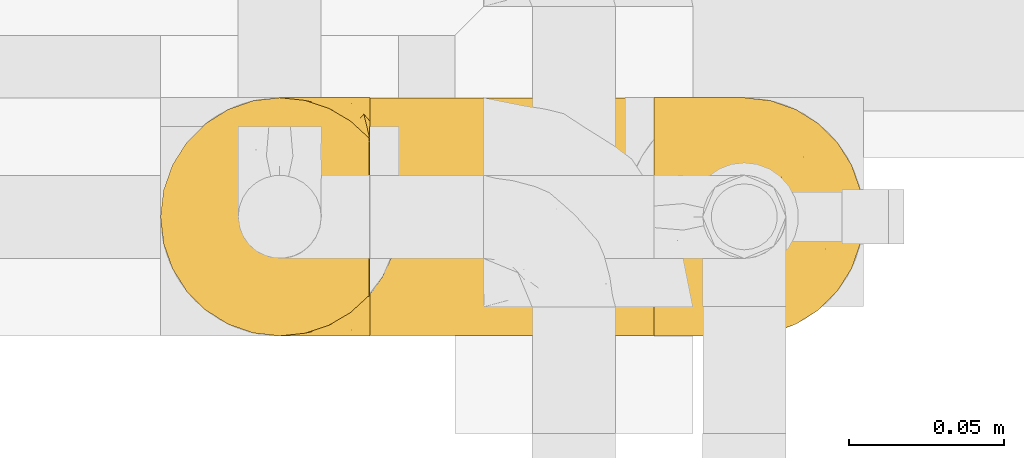
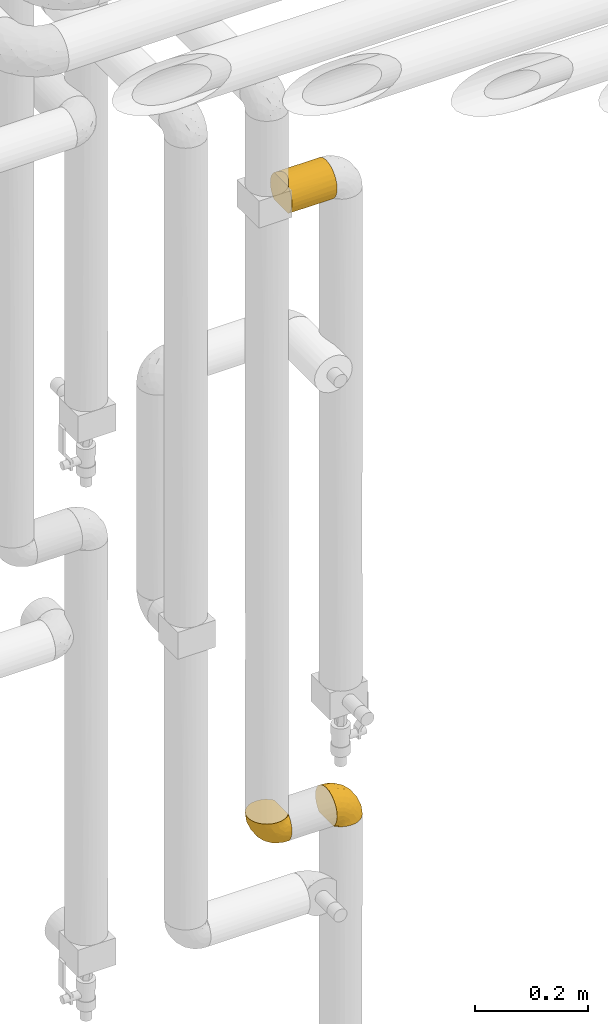
# One storey, part 279 of 827: 3 coverings.
"""IFC2X3 building model written with IfcOpenShell, lengths in millimetres."""

from ifc_helpers import new_model, entity, si_unit, converted_unit, derived_unit, direction, frame, origin, place, context, subcontext, project, spatial, faceted_brep, element, save


model = new_model("IFC2X3")

# Units and contexts
model_context = context("Model", 3, precision=0.01, world=origin(), true_north=direction((6.12303176911189e-17, 1.0)))
body_context = subcontext(model_context, "Body", "Model", "MODEL_VIEW")
ifc_project = project(units=[si_unit("LENGTHUNIT", "METRE", prefix="MILLI"), si_unit("AREAUNIT", "SQUARE_METRE"), si_unit("VOLUMEUNIT", "CUBIC_METRE"), converted_unit("PLANEANGLEUNIT", "DEGREE", entity("IfcRatioMeasure", 0.0174532925199433), si_unit("PLANEANGLEUNIT", "RADIAN"), dimensions=[0, 0, 0, 0, 0, 0, 0]), si_unit("MASSUNIT", "GRAM", prefix="KILO"), derived_unit("MASSDENSITYUNIT", [(si_unit("MASSUNIT", "GRAM", prefix="KILO"), 1), (si_unit("LENGTHUNIT", "METRE"), -3)]), derived_unit("MOMENTOFINERTIAUNIT", [(si_unit("LENGTHUNIT", "METRE"), 4)]), si_unit("TIMEUNIT", "SECOND"), si_unit("FREQUENCYUNIT", "HERTZ"), si_unit("THERMODYNAMICTEMPERATUREUNIT", "DEGREE_CELSIUS"), derived_unit("THERMALTRANSMITTANCEUNIT", [(si_unit("MASSUNIT", "GRAM", prefix="KILO"), 1), (si_unit("THERMODYNAMICTEMPERATUREUNIT", "KELVIN"), -1), (si_unit("TIMEUNIT", "SECOND"), -3)]), derived_unit("VOLUMETRICFLOWRATEUNIT", [(si_unit("LENGTHUNIT", "METRE"), 3), (si_unit("TIMEUNIT", "SECOND"), -1)]), derived_unit("MASSFLOWRATEUNIT", [(si_unit("MASSUNIT", "GRAM", prefix="KILO"), 1), (si_unit("TIMEUNIT", "SECOND"), -1)]), derived_unit("ROTATIONALFREQUENCYUNIT", [(si_unit("TIMEUNIT", "SECOND"), -1)]), si_unit("ELECTRICCURRENTUNIT", "AMPERE"), si_unit("ELECTRICVOLTAGEUNIT", "VOLT"), si_unit("POWERUNIT", "WATT"), si_unit("FORCEUNIT", "NEWTON", prefix="KILO"), si_unit("ILLUMINANCEUNIT", "LUX"), si_unit("LUMINOUSFLUXUNIT", "LUMEN"), si_unit("LUMINOUSINTENSITYUNIT", "CANDELA"), derived_unit("USERDEFINED", [(si_unit("MASSUNIT", "GRAM", prefix="KILO"), -1), (si_unit("LENGTHUNIT", "METRE"), -2), (si_unit("TIMEUNIT", "SECOND"), 3), (si_unit("LUMINOUSFLUXUNIT", "LUMEN"), 1)]), derived_unit("LINEARVELOCITYUNIT", [(si_unit("LENGTHUNIT", "METRE"), 1), (si_unit("TIMEUNIT", "SECOND"), -1)]), si_unit("PRESSUREUNIT", "PASCAL"), derived_unit("USERDEFINED", [(si_unit("LENGTHUNIT", "METRE"), -2), (si_unit("MASSUNIT", "GRAM", prefix="KILO"), 1), (si_unit("TIMEUNIT", "SECOND"), -2)]), derived_unit("LINEARFORCEUNIT", [(si_unit("MASSUNIT", "GRAM", prefix="KILO"), 1), (si_unit("LENGTHUNIT", "METRE"), 1), (si_unit("TIMEUNIT", "SECOND"), -2), (si_unit("LENGTHUNIT", "METRE"), -1)]), derived_unit("PLANARFORCEUNIT", [(si_unit("MASSUNIT", "GRAM", prefix="KILO"), 1), (si_unit("LENGTHUNIT", "METRE"), 1), (si_unit("TIMEUNIT", "SECOND"), -2), (si_unit("LENGTHUNIT", "METRE"), -2)])], contexts=[model_context])

# Site, building, storey
site_placement = place(None, origin())
site = spatial("IfcSite", under=ifc_project, at=site_placement, CompositionType="ELEMENT")
building_placement = place(site_placement, origin())
building = spatial("IfcBuilding", under=site, at=building_placement, CompositionType="ELEMENT")
storey_placement = place(building_placement, frame((0.0, 0.0, 28200.0)))
storey = spatial("IfcBuildingStorey", under=building, at=storey_placement, Name="08", CompositionType="ELEMENT", Elevation=28200.0)

# Coverings
covering_1_placement = place(storey_placement, frame((35112.19, 14884.87, 1199.3)))
element("IfcCovering", 1, at=covering_1_placement, inside=storey, Name=":ADSK_", ObjectType=":ADSK_", PredefinedType="INSULATION", context=body_context, shape_type="Brep", body=[
    faceted_brep([(47.38, 74.68, 1.6), (54.67, 70.1, 1.6), (60.76, 64.01, 1.6), (65.34, 56.72, 1.6), (68.18, 48.6, 1.6), (69.15, 40.05, 1.6), (68.18, 31.49, 1.6), (65.33, 23.36, 1.6), (60.75, 16.07, 1.6), (54.66, 9.98, 1.6), (47.37, 5.4, 1.6), (39.25, 2.56, 1.6), (30.7, 1.6, 1.6), (22.59, 2.46, 1.6), (14.86, 5.01, 1.6), (7.84, 9.13, 1.6), (1.85, 14.62, 1.6), (1.85, 16.82, 1.6), (1.85, 18.56, 1.6), (1.85, 20.52, 1.6), (1.85, 22.49, 1.6), (1.85, 24.46, 1.6), (1.85, 26.42, 1.6), (1.85, 28.39, 1.6), (1.85, 30.36, 1.6), (1.85, 32.55, 1.6), (1.85, 34.75, 1.6), (1.85, 36.94, 1.6), (1.85, 39.13, 1.6), (1.85, 41.33, 1.6), (1.85, 43.52, 1.6), (1.85, 45.72, 1.6), (1.85, 47.91, 1.6), (1.85, 50.11, 1.6), (1.85, 52.3, 1.6), (1.85, 54.49, 1.6), (1.85, 56.69, 1.6), (1.85, 58.88, 1.6), (1.85, 61.08, 1.6), (1.85, 63.27, 1.6), (1.85, 65.47, 1.6), (7.85, 70.97, 1.6), (14.88, 75.09, 1.6), (22.61, 77.64, 1.6), (30.7, 78.5, 1.6), (39.26, 77.53, 1.6), (1.6, 14.62, 1.85), (1.6, 9.12, 7.85), (1.6, 5.0, 14.87), (1.6, 2.46, 22.6), (1.6, 1.6, 30.7), (1.6, 2.91, 40.65), (1.6, 6.75, 49.92), (1.6, 12.86, 57.88), (1.6, 20.82, 63.99), (1.6, 30.09, 67.84), (1.6, 40.05, 69.15), (1.6, 50.0, 67.84), (1.6, 59.27, 63.99), (1.6, 67.23, 57.88), (1.6, 73.34, 49.92), (1.6, 77.19, 40.65), (1.6, 78.5, 30.7), (1.6, 77.63, 22.6), (1.6, 75.09, 14.87), (1.6, 70.97, 7.85), (1.6, 65.47, 1.85), (1.6, 63.27, 1.85), (1.6, 62.29, 1.85), (1.6, 60.7, 1.85), (1.6, 59.11, 1.85), (1.6, 57.52, 1.85), (1.6, 55.93, 1.85), (1.6, 54.34, 1.85), (1.6, 52.76, 1.85), (1.6, 51.17, 1.85), (1.6, 49.58, 1.85), (1.6, 47.99, 1.85), (1.6, 46.4, 1.85), (1.6, 44.81, 1.85), (1.6, 43.22, 1.85), (1.6, 41.63, 1.85), (1.6, 40.05, 1.85), (1.6, 38.46, 1.85), (1.6, 36.87, 1.85), (1.6, 35.28, 1.85), (1.6, 33.69, 1.85), (1.6, 32.1, 1.85), (1.6, 30.51, 1.85), (1.6, 28.92, 1.85), (1.6, 27.33, 1.85), (1.6, 25.37, 1.85), (1.6, 23.4, 1.85), (1.6, 21.21, 1.85), (1.6, 19.01, 1.85), (1.6, 16.82, 1.85), (1.78, 42.32, 1.77), (1.77, 44.02, 1.78), (1.78, 47.13, 1.77), (1.77, 48.74, 1.77), (1.79, 23.57, 1.76), (1.78, 25.13, 1.77), (1.76, 61.34, 1.79), (1.77, 22.02, 1.78), (1.77, 29.72, 1.78), (1.76, 56.73, 1.78), (1.77, 55.14, 1.78), (1.77, 37.66, 1.78), (1.8, 64.12, 1.74), (1.76, 28.13, 1.78), (1.77, 26.62, 1.78), (1.78, 31.46, 1.77), (1.77, 16.16, 1.78), (1.77, 39.16, 1.78), (1.76, 50.37, 1.78), (1.77, 17.69, 1.77), (1.78, 19.17, 1.77), (1.77, 62.78, 1.77), (1.77, 58.35, 1.78), (1.77, 45.53, 1.78), (1.78, 59.91, 1.77), (1.77, 65.47, 1.77), (1.8, 65.47, 1.72), (1.82, 65.47, 1.66), (1.77, 14.62, 1.77), (1.72, 14.62, 1.8), (1.66, 14.62, 1.82), (1.76, 20.59, 1.79), (1.77, 32.99, 1.78), (1.76, 34.48, 1.79), (1.77, 51.91, 1.78), (1.66, 65.47, 1.82), (1.72, 65.47, 1.8), (1.78, 53.48, 1.76), (1.82, 14.62, 1.66), (1.8, 14.62, 1.72), (1.77, 40.77, 1.78), (1.78, 35.97, 1.77), (3.72, 7.84, 9.41), (7.41, 3.53, 17.65), (6.13, 8.32, 7.41), (21.47, 1.6, 21.47), (19.34, 2.19, 15.21), (26.8, 1.6, 16.15), (8.87, 1.6, 28.75), (9.2, 4.57, 13.67), (12.79, 3.96, 12.79), (14.62, 2.28, 19.18), (7.34, 1.6, 29.16), (5.33, 7.69, 9.04), (17.64, 3.53, 7.41), (7.7, 8.32, 5.74), (9.41, 7.84, 3.72), (28.75, 1.6, 8.87), (16.15, 1.6, 26.8), (14.14, 4.34, 9.53), (29.16, 1.6, 7.34), (57.02, 29.63, 37.63), (64.92, 27.34, 17.92), (64.0, 40.05, 27.45), (11.92, 2.39, 37.01), (19.16, 2.43, 34.22), (28.65, 9.07, 45.87), (24.62, 16.64, 56.57), (15.19, 9.54, 52.31), (18.36, 4.52, 42.07), (9.2, 4.52, 44.74), (46.98, 7.49, 21.49), (50.24, 7.49, 11.02), (56.1, 12.85, 15.64), (28.97, 2.35, 26.02), (54.46, 22.66, 36.59), (21.34, 32.9, 65.49), (18.4, 25.33, 63.99), (66.44, 40.05, 15.2), (12.07, 16.64, 60.27), (45.49, 19.99, 45.25), (50.57, 16.37, 35.21), (36.04, 3.26, 22.52), (42.07, 3.75, 12.03), (62.12, 19.58, 13.32), (37.37, 7.5, 35.9), (29.39, 4.04, 33.87), (53.59, 13.94, 25.73), (58.06, 19.58, 26.34), (49.27, 28.21, 46.78), (29.63, 24.75, 59.54), (33.21, 31.42, 60.18), (40.1, 26.2, 53.93), (44.08, 33.36, 53.36), (49.36, 40.05, 49.36), (56.68, 40.05, 38.4), (15.2, 40.05, 66.44), (35.57, 16.14, 50.09), (41.7, 12.85, 41.08), (46.4, 10.47, 31.14), (41.41, 6.49, 28.19), (27.45, 40.05, 64.0), (38.4, 40.05, 56.68), (12.99, 75.57, 43.9), (21.33, 47.37, 65.46), (42.89, 52.91, 52.22), (57.04, 50.46, 37.61), (56.11, 67.23, 15.64), (62.13, 60.5, 13.31), (21.89, 70.55, 50.02), (16.62, 63.45, 59.28), (32.9, 62.61, 53.05), (46.99, 72.6, 21.48), (50.25, 72.6, 11.01), (42.08, 76.34, 12.03), (49.91, 59.34, 41.02), (15.6, 77.76, 35.39), (16.15, 78.5, 26.8), (8.87, 78.5, 28.75), (29.16, 78.5, 7.34), (13.16, 53.16, 65.81), (10.83, 70.55, 53.28), (33.8, 48.88, 59.8), (25.02, 54.76, 61.82), (64.92, 52.74, 17.91), (32.83, 71.93, 41.4), (20.56, 75.79, 40.48), (58.07, 60.5, 26.34), (21.46, 77.86, 31.68), (28.1, 77.64, 27.68), (26.8, 78.5, 16.15), (21.47, 78.5, 21.47), (51.29, 67.23, 28.05), (36.04, 76.82, 22.54), (28.75, 78.5, 8.87), (8.45, 77.8, 37.3), (41.73, 67.23, 41.07), (39.27, 73.2, 32.24), (33.56, 67.66, 47.4), (27.29, 75.99, 35.77), (7.41, 76.57, 17.65), (3.51, 73.21, 11.06), (4.68, 71.93, 8.55), (5.52, 71.07, 6.63), (8.75, 75.09, 12.77), (12.79, 76.13, 12.79), (17.65, 76.57, 7.41), (13.9, 77.69, 18.97), (9.42, 72.26, 3.72), (7.68, 71.77, 5.76), (19.33, 77.9, 15.21), (14.13, 75.75, 9.52)], [[[0, 1, 2, 3, 4, 5, 6, 7, 8, 9, 10, 11, 12, 13, 14, 15, 16, 17, 18, 19, 20, 21, 22, 23, 24, 25, 26, 27, 28, 29, 30, 31, 32, 33, 34, 35, 36, 37, 38, 39, 40, 41, 42, 43, 44, 45]], [[46, 47, 48, 49, 50, 51, 52, 53, 54, 55, 56, 57, 58, 59, 60, 61, 62, 63, 64, 65, 66, 67, 68, 69, 70, 71, 72, 73, 74, 75, 76, 77, 78, 79, 80, 81, 82, 83, 84, 85, 86, 87, 88, 89, 90, 91, 92, 93, 94, 95]], [[96, 97, 30]], [[98, 77, 99]], [[100, 101, 21]], [[69, 68, 102]], [[20, 19, 103]], [[24, 23, 104]], [[20, 103, 100]], [[72, 105, 106]], [[84, 83, 107]], [[89, 88, 104]], [[108, 67, 66]], [[109, 110, 90]], [[111, 25, 24]], [[112, 17, 16]], [[82, 113, 83]], [[109, 23, 22]], [[114, 76, 75]], [[105, 36, 106]], [[104, 111, 24]], [[18, 115, 116]], [[97, 96, 80]], [[67, 108, 117]], [[105, 71, 118]], [[31, 97, 119]], [[102, 120, 69]], [[108, 121, 122, 123, 40]], [[112, 95, 115]], [[17, 115, 18]], [[94, 116, 115]], [[117, 68, 67]], [[38, 117, 39]], [[112, 124, 125, 126, 46]], [[17, 112, 115]], [[70, 120, 118]], [[39, 117, 108]], [[120, 38, 37]], [[120, 37, 118]], [[120, 70, 69]], [[116, 94, 127]], [[128, 86, 129]], [[117, 38, 102]], [[74, 130, 75]], [[99, 33, 32]], [[115, 95, 94]], [[39, 108, 40]], [[108, 66, 131, 132, 121]], [[105, 72, 71]], [[118, 37, 36]], [[71, 70, 118]], [[35, 106, 36]], [[36, 105, 118]], [[35, 133, 106]], [[74, 73, 133]], [[106, 133, 73]], [[99, 114, 33]], [[133, 35, 34]], [[73, 72, 106]], [[95, 112, 46]], [[112, 16, 134, 135, 124]], [[130, 114, 75]], [[99, 76, 114]], [[114, 130, 33]], [[34, 33, 130]], [[78, 77, 98]], [[98, 119, 78]], [[130, 133, 34]], [[133, 130, 74]], [[79, 97, 80]], [[98, 99, 32]], [[98, 32, 31]], [[77, 76, 99]], [[97, 79, 119]], [[136, 96, 29]], [[30, 97, 31]], [[136, 29, 28]], [[81, 80, 96]], [[29, 96, 30]], [[31, 119, 98]], [[119, 79, 78]], [[96, 136, 81]], [[82, 81, 136]], [[113, 107, 83]], [[84, 107, 137]], [[107, 27, 137]], [[113, 28, 107]], [[27, 107, 28]], [[85, 84, 137]], [[137, 27, 26]], [[113, 136, 28]], [[136, 113, 82]], [[109, 89, 104]], [[86, 85, 129]], [[89, 109, 90]], [[111, 87, 128]], [[26, 129, 137]], [[88, 111, 104]], [[25, 111, 128]], [[22, 110, 109]], [[23, 109, 104]], [[110, 91, 90]], [[100, 92, 101]], [[110, 22, 101]], [[91, 110, 101]], [[116, 19, 18]], [[111, 88, 87]], [[127, 103, 19]], [[25, 128, 26]], [[86, 128, 87]], [[128, 129, 26]], [[137, 129, 85]], [[120, 102, 38]], [[117, 102, 68]], [[91, 101, 92]], [[21, 101, 22]], [[93, 92, 103]], [[100, 21, 20]], [[100, 103, 92]], [[127, 93, 103]], [[93, 127, 94]], [[116, 127, 19]], [[126, 138, 47]], [[48, 138, 139]], [[140, 125, 124]], [[141, 142, 143]], [[144, 49, 139]], [[145, 140, 146]], [[48, 139, 49]], [[139, 145, 147]], [[49, 144, 148, 50]], [[126, 125, 149]], [[14, 13, 150]], [[151, 146, 140]], [[149, 140, 145]], [[152, 151, 135]], [[152, 14, 150]], [[16, 15, 134]], [[13, 153, 150]], [[124, 151, 140]], [[141, 147, 142]], [[14, 152, 15]], [[15, 152, 134]], [[47, 46, 126]], [[139, 154, 144]], [[138, 48, 47]], [[125, 140, 149]], [[135, 134, 152]], [[146, 155, 142]], [[145, 146, 147]], [[149, 139, 138]], [[147, 141, 154]], [[147, 146, 142]], [[139, 147, 154]], [[139, 149, 145]], [[149, 138, 126]], [[155, 146, 151]], [[150, 143, 142]], [[152, 155, 151]], [[150, 142, 155]], [[13, 12, 156, 153]], [[153, 143, 150]], [[152, 150, 155]], [[151, 124, 135]], [[157, 158, 159]], [[160, 154, 161]], [[162, 163, 164]], [[165, 166, 160]], [[167, 168, 169]], [[141, 170, 161]], [[156, 12, 11]], [[158, 157, 171]], [[172, 55, 173]], [[158, 6, 174]], [[175, 54, 53]], [[52, 166, 164]], [[52, 164, 53]], [[54, 175, 173]], [[166, 52, 51]], [[176, 177, 171]], [[178, 143, 179]], [[156, 11, 179]], [[8, 7, 180]], [[169, 9, 8]], [[179, 143, 153, 156]], [[179, 11, 10]], [[168, 179, 10]], [[181, 162, 182]], [[179, 167, 178]], [[183, 184, 177]], [[183, 169, 184]], [[176, 171, 185]], [[172, 186, 187]], [[158, 7, 6]], [[159, 158, 174]], [[184, 180, 158]], [[54, 173, 55]], [[180, 169, 8]], [[188, 189, 187]], [[9, 168, 10]], [[186, 188, 187]], [[190, 157, 159, 191]], [[55, 172, 192]], [[176, 193, 194]], [[161, 170, 182]], [[162, 164, 165]], [[175, 164, 163]], [[51, 50, 148]], [[167, 195, 196]], [[178, 182, 170]], [[6, 5, 174]], [[158, 180, 7]], [[169, 180, 184]], [[169, 168, 9]], [[179, 168, 167]], [[182, 162, 165]], [[162, 194, 193]], [[161, 165, 160]], [[195, 181, 196]], [[192, 172, 197]], [[192, 56, 55]], [[189, 190, 198]], [[198, 197, 187]], [[172, 187, 197]], [[185, 189, 188]], [[198, 187, 189]], [[186, 172, 173]], [[173, 163, 186]], [[193, 186, 163]], [[176, 185, 188]], [[185, 157, 190]], [[188, 186, 193]], [[177, 176, 194]], [[188, 193, 176]], [[162, 193, 163]], [[195, 177, 194]], [[171, 177, 184]], [[181, 195, 194]], [[183, 167, 169]], [[162, 181, 194]], [[196, 182, 178]], [[158, 171, 184]], [[171, 157, 185]], [[177, 195, 183]], [[167, 183, 195]], [[182, 196, 181]], [[178, 170, 143]], [[178, 167, 196]], [[164, 175, 53]], [[173, 175, 163]], [[160, 51, 148]], [[164, 166, 165]], [[51, 160, 166]], [[160, 148, 144, 154]], [[141, 161, 154]], [[182, 165, 161]], [[190, 189, 185]], [[143, 170, 141]], [[60, 199, 61]], [[197, 200, 192]], [[201, 190, 202]], [[200, 57, 192]], [[203, 204, 2]], [[205, 206, 207]], [[208, 209, 210]], [[211, 207, 201]], [[212, 213, 214]], [[45, 215, 210]], [[216, 206, 58]], [[45, 44, 215]], [[59, 217, 60]], [[60, 217, 199]], [[0, 45, 210]], [[218, 201, 219]], [[202, 159, 220]], [[205, 221, 222]], [[223, 204, 203]], [[1, 203, 2]], [[57, 200, 216]], [[220, 3, 204]], [[220, 174, 4]], [[1, 0, 209]], [[212, 224, 213]], [[225, 226, 227]], [[228, 223, 203]], [[208, 210, 229]], [[210, 226, 229]], [[3, 220, 4]], [[58, 206, 59]], [[209, 203, 1]], [[202, 220, 223]], [[228, 203, 208]], [[202, 211, 201]], [[3, 2, 204]], [[202, 190, 191, 159]], [[210, 215, 230, 226]], [[199, 212, 231]], [[232, 233, 221]], [[233, 208, 229]], [[207, 206, 219]], [[217, 206, 205]], [[227, 224, 225]], [[233, 232, 228]], [[201, 207, 219]], [[234, 232, 221]], [[218, 219, 200]], [[202, 223, 211]], [[174, 220, 159]], [[174, 5, 4]], [[61, 231, 62]], [[220, 204, 223]], [[210, 209, 0]], [[203, 209, 208]], [[225, 233, 229]], [[224, 227, 213]], [[221, 233, 235]], [[57, 56, 192]], [[198, 218, 197]], [[200, 219, 216]], [[201, 198, 190]], [[197, 218, 200]], [[198, 201, 218]], [[206, 216, 219]], [[58, 57, 216]], [[231, 212, 214]], [[222, 212, 199]], [[228, 211, 223]], [[207, 211, 232]], [[62, 231, 214]], [[199, 231, 61]], [[233, 228, 208]], [[211, 228, 232]], [[222, 221, 235]], [[234, 205, 207]], [[206, 217, 59]], [[199, 217, 205]], [[205, 222, 199]], [[224, 222, 235]], [[222, 224, 212]], [[224, 235, 225]], [[233, 225, 235]], [[226, 225, 229]], [[205, 234, 221]], [[207, 232, 234]], [[63, 214, 236]], [[214, 213, 236]], [[214, 63, 62]], [[237, 236, 238]], [[238, 132, 131]], [[236, 237, 64]], [[239, 240, 241]], [[63, 236, 64]], [[131, 66, 65]], [[237, 131, 65]], [[242, 230, 43]], [[237, 65, 64]], [[239, 121, 132]], [[42, 242, 43]], [[241, 240, 243]], [[41, 123, 244]], [[43, 230, 215, 44]], [[244, 122, 245]], [[227, 246, 243]], [[241, 247, 245]], [[121, 239, 245]], [[41, 40, 123]], [[132, 238, 239]], [[244, 42, 41]], [[131, 237, 238]], [[240, 239, 238]], [[245, 239, 241]], [[247, 241, 246]], [[247, 244, 245]], [[238, 236, 240]], [[243, 236, 213]], [[236, 243, 240]], [[227, 226, 246]], [[243, 213, 227]], [[242, 246, 226]], [[243, 246, 241]], [[246, 242, 247]], [[244, 247, 242]], [[242, 226, 230]], [[42, 244, 242]], [[122, 244, 123]], [[122, 121, 245]]]),
])
covering_2_placement = place(storey_placement, frame((35020.29, 14884.92, 2540.0)))
element("IfcCovering", 2, at=covering_2_placement, inside=storey, Name=":ADSK_", ObjectType=":ADSK_", PredefinedType="INSULATION", context=body_context, shape_type="Brep", body=[
    faceted_brep([(93.5, 77.51, 31.79), (93.5, 78.4, 40.0), (93.5, 77.09, 49.93), (93.5, 73.25, 59.2), (93.5, 67.15, 67.15), (93.5, 59.2, 73.25), (93.5, 49.93, 77.09), (93.5, 40.0, 78.4), (93.5, 30.06, 77.09), (93.5, 20.8, 73.25), (93.5, 12.84, 67.15), (93.5, 6.74, 59.2), (93.5, 2.9, 49.93), (93.5, 1.6, 40.0), (93.5, 2.48, 31.79), (93.5, 5.09, 23.98), (93.5, 9.31, 16.91), (93.5, 14.94, 10.9), (93.5, 65.05, 10.9), (93.5, 70.68, 16.91), (93.5, 74.9, 23.98), (1.6, 78.4, 40.0), (1.6, 77.52, 31.83), (1.6, 74.93, 24.05), (1.6, 70.75, 17.0), (1.6, 65.17, 11.0), (1.6, 14.82, 11.0), (1.6, 9.24, 17.0), (1.6, 5.06, 24.05), (1.6, 2.47, 31.83), (1.6, 1.6, 40.0), (1.6, 2.47, 48.16), (1.6, 5.06, 55.94), (1.6, 9.24, 62.99), (1.6, 14.82, 69.0), (1.6, 65.17, 69.0), (1.6, 70.75, 62.99), (1.6, 74.93, 55.94), (1.6, 77.52, 48.16), (5.61, 20.38, 6.98), (8.57, 26.56, 4.02), (89.52, 20.48, 6.92), (10.38, 33.17, 2.21), (11.0, 40.0, 1.6), (84.8, 33.21, 2.2), (86.6, 26.63, 4.0), (84.2, 40.0, 1.6), (10.38, 46.82, 2.21), (84.8, 46.78, 2.2), (8.57, 53.43, 4.02), (5.61, 59.61, 6.98), (89.52, 59.51, 6.92), (86.6, 53.36, 4.0), (5.61, 59.61, 73.01), (8.57, 53.43, 75.97), (10.38, 46.82, 77.78), (11.0, 40.0, 78.4), (10.38, 33.17, 77.78), (8.57, 26.56, 75.97), (5.61, 20.38, 73.01)], [[[0, 1, 2, 3, 4, 5, 6, 7, 8, 9, 10, 11, 12, 13, 14, 15, 16, 17, 18, 19, 20]], [[21, 22, 23, 24, 25, 26, 27, 28, 29, 30, 31, 32, 33, 34, 35, 36, 37, 38]], [[30, 29, 13]], [[27, 26, 16]], [[13, 29, 14]], [[27, 15, 28]], [[15, 27, 16]], [[28, 15, 14]], [[29, 28, 14]], [[26, 17, 16]], [[39, 40, 41]], [[42, 43, 44]], [[40, 42, 45]], [[41, 17, 39]], [[44, 45, 42]], [[46, 44, 43]], [[41, 40, 45]], [[39, 17, 26]], [[43, 47, 48]], [[49, 50, 51]], [[47, 49, 52]], [[48, 46, 43]], [[51, 52, 49]], [[18, 51, 50]], [[48, 47, 52]], [[50, 25, 18]], [[20, 24, 23]], [[0, 23, 22]], [[1, 22, 21]], [[25, 19, 18]], [[25, 24, 19]], [[20, 19, 24]], [[23, 0, 20]], [[22, 1, 0]], [[1, 21, 38]], [[2, 38, 37]], [[3, 37, 36]], [[1, 38, 2]], [[2, 37, 3]], [[36, 4, 3]], [[36, 35, 4]], [[35, 53, 5]], [[54, 55, 6]], [[53, 54, 5]], [[5, 54, 6]], [[7, 6, 55]], [[56, 7, 55]], [[35, 5, 4]], [[57, 58, 8]], [[59, 34, 9]], [[58, 59, 9]], [[56, 57, 7]], [[7, 57, 8]], [[58, 9, 8]], [[34, 10, 9]], [[11, 33, 32]], [[12, 32, 31]], [[13, 31, 30]], [[10, 33, 11]], [[11, 32, 12]], [[31, 13, 12]], [[33, 10, 34]], [[48, 52, 51, 18, 17, 41, 45, 44, 46]], [[34, 59, 58, 57, 56, 55, 54, 53, 35]], [[25, 50, 49, 47, 43, 42, 40, 39, 26]]]),
])
covering_3_placement = place(storey_placement, frame((34952.84, 14884.87, 1189.95)))
element("IfcCovering", 3, at=covering_3_placement, inside=storey, Name=":ADSK_", ObjectType=":ADSK_", PredefinedType="INSULATION", context=body_context, shape_type="Brep", body=[
    faceted_brep([(23.36, 74.68, 69.15), (16.07, 70.1, 69.15), (9.98, 64.01, 69.15), (5.4, 56.72, 69.15), (2.56, 48.6, 69.15), (1.6, 40.05, 69.15), (2.56, 31.49, 69.15), (5.41, 23.36, 69.15), (9.99, 16.07, 69.15), (16.08, 9.98, 69.15), (23.37, 5.4, 69.15), (31.49, 2.56, 69.15), (40.05, 1.6, 69.15), (48.15, 2.46, 69.15), (55.88, 5.01, 69.15), (62.9, 9.13, 69.15), (68.89, 14.62, 69.15), (68.89, 16.82, 69.15), (68.89, 18.56, 69.15), (68.89, 20.52, 69.15), (68.89, 22.49, 69.15), (68.89, 24.46, 69.15), (68.89, 26.42, 69.15), (68.89, 28.39, 69.15), (68.89, 30.36, 69.15), (68.89, 32.55, 69.15), (68.89, 34.75, 69.15), (68.89, 36.94, 69.15), (68.89, 39.13, 69.15), (68.89, 41.33, 69.15), (68.89, 43.52, 69.15), (68.89, 45.72, 69.15), (68.89, 47.91, 69.15), (68.89, 50.11, 69.15), (68.89, 52.3, 69.15), (68.89, 54.49, 69.15), (68.89, 56.69, 69.15), (68.89, 58.88, 69.15), (68.89, 61.08, 69.15), (68.89, 63.27, 69.15), (68.89, 65.47, 69.15), (62.89, 70.97, 69.15), (55.86, 75.09, 69.15), (48.13, 77.64, 69.15), (40.05, 78.5, 69.15), (31.49, 77.53, 69.15), (69.15, 14.62, 68.89), (69.15, 9.12, 62.89), (69.15, 5.0, 55.87), (69.15, 2.46, 48.14), (69.15, 1.6, 40.05), (69.15, 2.91, 30.09), (69.15, 6.75, 20.82), (69.15, 12.86, 12.86), (69.15, 20.82, 6.75), (69.15, 30.09, 2.91), (69.15, 40.05, 1.6), (69.15, 50.0, 2.91), (69.15, 59.27, 6.75), (69.15, 67.23, 12.86), (69.15, 73.34, 20.82), (69.15, 77.19, 30.09), (69.15, 78.5, 40.05), (69.15, 77.63, 48.14), (69.15, 75.09, 55.87), (69.15, 70.97, 62.89), (69.15, 65.47, 68.89), (69.15, 63.27, 68.89), (69.15, 62.29, 68.89), (69.15, 60.7, 68.89), (69.15, 59.11, 68.89), (69.15, 57.52, 68.89), (69.15, 55.93, 68.89), (69.15, 54.34, 68.89), (69.15, 52.76, 68.89), (69.15, 51.17, 68.89), (69.15, 49.58, 68.89), (69.15, 47.99, 68.89), (69.15, 46.4, 68.89), (69.15, 44.81, 68.89), (69.15, 43.22, 68.89), (69.15, 41.63, 68.89), (69.15, 40.05, 68.89), (69.15, 38.46, 68.89), (69.15, 36.87, 68.89), (69.15, 35.28, 68.89), (69.15, 33.69, 68.89), (69.15, 32.1, 68.89), (69.15, 30.51, 68.89), (69.15, 28.92, 68.89), (69.15, 27.33, 68.89), (69.15, 25.37, 68.89), (69.15, 23.4, 68.89), (69.15, 21.21, 68.89), (69.15, 19.01, 68.89), (69.15, 16.82, 68.89), (68.96, 42.32, 68.97), (68.97, 44.02, 68.96), (68.97, 47.13, 68.97), (68.97, 48.74, 68.97), (68.95, 23.57, 68.98), (68.96, 25.13, 68.97), (68.98, 61.34, 68.96), (68.97, 22.02, 68.96), (68.97, 29.72, 68.96), (68.98, 56.73, 68.96), (68.97, 55.14, 68.96), (68.97, 37.66, 68.96), (68.94, 64.12, 69.0), (68.98, 28.13, 68.96), (68.98, 26.62, 68.96), (68.96, 31.46, 68.97), (68.97, 16.16, 68.96), (68.98, 39.16, 68.96), (68.98, 50.37, 68.96), (68.97, 17.69, 68.97), (68.96, 19.17, 68.97), (68.97, 62.78, 68.97), (68.97, 58.35, 68.96), (68.98, 45.53, 68.96), (68.96, 59.91, 68.97), (68.97, 65.47, 68.97), (68.94, 65.47, 69.02), (68.92, 65.47, 69.08), (68.97, 14.62, 68.97), (69.02, 14.62, 68.94), (69.08, 14.62, 68.92), (68.98, 20.59, 68.96), (68.97, 32.99, 68.96), (68.98, 34.48, 68.95), (68.97, 51.91, 68.96), (69.08, 65.47, 68.92), (69.02, 65.47, 68.94), (68.96, 53.48, 68.98), (68.92, 14.62, 69.08), (68.94, 14.62, 69.02), (68.97, 40.77, 68.96), (68.96, 35.97, 68.97), (67.02, 7.84, 61.33), (63.33, 3.53, 53.1), (64.61, 8.32, 63.33), (49.27, 1.6, 49.27), (51.4, 2.19, 55.53), (43.94, 1.6, 54.6), (61.87, 1.6, 41.99), (61.54, 4.57, 57.07), (57.95, 3.96, 57.95), (56.12, 2.28, 51.56), (63.4, 1.6, 41.58), (65.41, 7.69, 61.7), (53.1, 3.53, 63.33), (63.04, 8.32, 65.0), (61.33, 7.84, 67.02), (41.99, 1.6, 61.87), (54.6, 1.6, 43.94), (56.6, 4.34, 61.21), (41.58, 1.6, 63.4), (13.72, 29.63, 33.11), (5.82, 27.34, 52.82), (6.74, 40.05, 43.3), (58.82, 2.39, 33.73), (51.58, 2.43, 36.52), (42.09, 9.07, 24.87), (46.12, 16.64, 14.17), (55.56, 9.54, 18.43), (52.38, 4.52, 28.67), (61.54, 4.52, 26.0), (23.76, 7.49, 49.25), (20.5, 7.49, 59.72), (14.64, 12.85, 55.1), (41.77, 2.35, 44.72), (16.28, 22.66, 34.15), (49.4, 32.9, 5.25), (52.34, 25.33, 6.75), (4.3, 40.05, 55.54), (58.67, 16.64, 10.47), (25.26, 19.99, 25.49), (20.17, 16.37, 35.53), (34.7, 3.26, 48.22), (28.67, 3.75, 58.71), (8.62, 19.58, 57.42), (33.37, 7.5, 34.84), (41.35, 4.04, 36.87), (17.15, 13.94, 45.01), (12.68, 19.58, 44.4), (21.47, 28.21, 23.96), (41.11, 24.75, 11.2), (37.53, 31.42, 10.56), (30.64, 26.2, 16.81), (26.66, 33.36, 17.38), (21.38, 40.05, 21.38), (14.06, 40.05, 32.34), (55.54, 40.05, 4.3), (35.17, 16.14, 20.65), (29.04, 12.85, 29.66), (24.34, 10.47, 39.6), (29.33, 6.49, 42.55), (43.3, 40.05, 6.74), (32.34, 40.05, 14.06), (57.75, 75.57, 26.84), (49.41, 47.37, 5.28), (27.85, 52.91, 18.52), (13.7, 50.46, 33.13), (14.63, 67.23, 55.1), (8.61, 60.5, 57.43), (48.85, 70.55, 20.72), (54.13, 63.45, 11.46), (37.84, 62.61, 17.69), (23.75, 72.6, 49.26), (20.49, 72.6, 59.73), (28.66, 76.34, 58.71), (20.83, 59.34, 29.72), (55.15, 77.76, 35.35), (54.6, 78.5, 43.94), (61.87, 78.5, 41.99), (41.58, 78.5, 63.4), (57.58, 53.16, 4.93), (59.91, 70.55, 17.46), (36.94, 48.88, 10.94), (45.72, 54.76, 8.92), (5.82, 52.74, 52.83), (37.91, 71.93, 29.34), (50.18, 75.79, 30.26), (12.67, 60.5, 44.4), (49.29, 77.86, 39.06), (42.64, 77.64, 43.06), (43.94, 78.5, 54.6), (49.27, 78.5, 49.27), (19.45, 67.23, 42.69), (34.7, 76.82, 48.2), (41.99, 78.5, 61.87), (62.29, 77.8, 33.44), (29.01, 67.23, 29.67), (31.47, 73.2, 38.5), (37.18, 67.66, 23.35), (43.45, 75.99, 34.97), (63.33, 76.57, 53.1), (67.23, 73.21, 59.68), (66.07, 71.93, 62.19), (65.22, 71.07, 64.11), (61.99, 75.09, 57.97), (57.95, 76.13, 57.95), (53.09, 76.57, 63.33), (56.84, 77.69, 51.77), (61.33, 72.26, 67.02), (63.06, 71.77, 64.98), (51.41, 77.9, 55.53), (56.61, 75.75, 61.22)], [[[0, 1, 2, 3, 4, 5, 6, 7, 8, 9, 10, 11, 12, 13, 14, 15, 16, 17, 18, 19, 20, 21, 22, 23, 24, 25, 26, 27, 28, 29, 30, 31, 32, 33, 34, 35, 36, 37, 38, 39, 40, 41, 42, 43, 44, 45]], [[46, 47, 48, 49, 50, 51, 52, 53, 54, 55, 56, 57, 58, 59, 60, 61, 62, 63, 64, 65, 66, 67, 68, 69, 70, 71, 72, 73, 74, 75, 76, 77, 78, 79, 80, 81, 82, 83, 84, 85, 86, 87, 88, 89, 90, 91, 92, 93, 94, 95]], [[96, 97, 30]], [[98, 77, 99]], [[100, 101, 21]], [[69, 68, 102]], [[20, 19, 103]], [[24, 23, 104]], [[20, 103, 100]], [[72, 105, 106]], [[84, 83, 107]], [[89, 88, 104]], [[108, 67, 66]], [[109, 110, 90]], [[111, 25, 24]], [[112, 17, 16]], [[82, 113, 83]], [[109, 23, 22]], [[114, 76, 75]], [[105, 36, 106]], [[104, 111, 24]], [[18, 115, 116]], [[97, 96, 80]], [[67, 108, 117]], [[105, 71, 118]], [[31, 97, 119]], [[102, 120, 69]], [[108, 121, 122, 123, 40]], [[112, 95, 115]], [[17, 115, 18]], [[94, 116, 115]], [[117, 68, 67]], [[38, 117, 39]], [[112, 124, 125, 126, 46]], [[17, 112, 115]], [[70, 120, 118]], [[39, 117, 108]], [[120, 38, 37]], [[120, 37, 118]], [[120, 70, 69]], [[116, 94, 127]], [[128, 86, 129]], [[117, 38, 102]], [[74, 130, 75]], [[99, 33, 32]], [[115, 95, 94]], [[39, 108, 40]], [[108, 66, 131, 132, 121]], [[105, 72, 71]], [[118, 37, 36]], [[71, 70, 118]], [[35, 106, 36]], [[36, 105, 118]], [[35, 133, 106]], [[74, 73, 133]], [[106, 133, 73]], [[99, 114, 33]], [[133, 35, 34]], [[73, 72, 106]], [[95, 112, 46]], [[112, 16, 134, 135, 124]], [[130, 114, 75]], [[99, 76, 114]], [[114, 130, 33]], [[34, 33, 130]], [[78, 77, 98]], [[98, 119, 78]], [[130, 133, 34]], [[133, 130, 74]], [[79, 97, 80]], [[98, 99, 32]], [[98, 32, 31]], [[77, 76, 99]], [[97, 79, 119]], [[136, 96, 29]], [[30, 97, 31]], [[136, 29, 28]], [[81, 80, 96]], [[29, 96, 30]], [[31, 119, 98]], [[119, 79, 78]], [[96, 136, 81]], [[82, 81, 136]], [[113, 107, 83]], [[84, 107, 137]], [[107, 27, 137]], [[113, 28, 107]], [[27, 107, 28]], [[85, 84, 137]], [[137, 27, 26]], [[113, 136, 28]], [[136, 113, 82]], [[109, 89, 104]], [[86, 85, 129]], [[89, 109, 90]], [[111, 87, 128]], [[26, 129, 137]], [[88, 111, 104]], [[25, 111, 128]], [[22, 110, 109]], [[23, 109, 104]], [[110, 91, 90]], [[100, 92, 101]], [[110, 22, 101]], [[91, 110, 101]], [[116, 19, 18]], [[111, 88, 87]], [[127, 103, 19]], [[25, 128, 26]], [[86, 128, 87]], [[128, 129, 26]], [[137, 129, 85]], [[120, 102, 38]], [[117, 102, 68]], [[91, 101, 92]], [[21, 101, 22]], [[93, 92, 103]], [[100, 21, 20]], [[100, 103, 92]], [[127, 93, 103]], [[93, 127, 94]], [[116, 127, 19]], [[126, 138, 47]], [[48, 138, 139]], [[140, 125, 124]], [[141, 142, 143]], [[144, 49, 139]], [[145, 140, 146]], [[48, 139, 49]], [[139, 145, 147]], [[49, 144, 148, 50]], [[126, 125, 149]], [[14, 13, 150]], [[151, 146, 140]], [[149, 140, 145]], [[152, 151, 135]], [[152, 14, 150]], [[16, 15, 134]], [[13, 153, 150]], [[124, 151, 140]], [[141, 147, 142]], [[14, 152, 15]], [[15, 152, 134]], [[47, 46, 126]], [[139, 154, 144]], [[138, 48, 47]], [[125, 140, 149]], [[135, 134, 152]], [[146, 155, 142]], [[145, 146, 147]], [[149, 139, 138]], [[147, 141, 154]], [[147, 146, 142]], [[139, 147, 154]], [[139, 149, 145]], [[149, 138, 126]], [[155, 146, 151]], [[150, 143, 142]], [[152, 155, 151]], [[150, 142, 155]], [[13, 12, 156, 153]], [[153, 143, 150]], [[152, 150, 155]], [[151, 124, 135]], [[157, 158, 159]], [[160, 154, 161]], [[162, 163, 164]], [[165, 166, 160]], [[167, 168, 169]], [[141, 170, 161]], [[156, 12, 11]], [[158, 157, 171]], [[172, 55, 173]], [[158, 6, 174]], [[175, 54, 53]], [[52, 166, 164]], [[52, 164, 53]], [[54, 175, 173]], [[166, 52, 51]], [[176, 177, 171]], [[178, 143, 179]], [[156, 11, 179]], [[8, 7, 180]], [[169, 9, 8]], [[179, 143, 153, 156]], [[179, 11, 10]], [[168, 179, 10]], [[181, 162, 182]], [[179, 167, 178]], [[183, 184, 177]], [[183, 169, 184]], [[176, 171, 185]], [[172, 186, 187]], [[158, 7, 6]], [[159, 158, 174]], [[184, 180, 158]], [[54, 173, 55]], [[180, 169, 8]], [[188, 189, 187]], [[9, 168, 10]], [[186, 188, 187]], [[190, 157, 159, 191]], [[55, 172, 192]], [[176, 193, 194]], [[161, 170, 182]], [[162, 164, 165]], [[175, 164, 163]], [[51, 50, 148]], [[167, 195, 196]], [[178, 182, 170]], [[6, 5, 174]], [[158, 180, 7]], [[169, 180, 184]], [[169, 168, 9]], [[179, 168, 167]], [[182, 162, 165]], [[162, 194, 193]], [[161, 165, 160]], [[195, 181, 196]], [[192, 172, 197]], [[192, 56, 55]], [[189, 190, 198]], [[198, 197, 187]], [[172, 187, 197]], [[185, 189, 188]], [[198, 187, 189]], [[186, 172, 173]], [[173, 163, 186]], [[193, 186, 163]], [[176, 185, 188]], [[185, 157, 190]], [[188, 186, 193]], [[177, 176, 194]], [[188, 193, 176]], [[162, 193, 163]], [[195, 177, 194]], [[171, 177, 184]], [[181, 195, 194]], [[183, 167, 169]], [[162, 181, 194]], [[196, 182, 178]], [[158, 171, 184]], [[171, 157, 185]], [[177, 195, 183]], [[167, 183, 195]], [[182, 196, 181]], [[178, 170, 143]], [[178, 167, 196]], [[164, 175, 53]], [[173, 175, 163]], [[160, 51, 148]], [[164, 166, 165]], [[51, 160, 166]], [[160, 148, 144, 154]], [[141, 161, 154]], [[182, 165, 161]], [[190, 189, 185]], [[143, 170, 141]], [[60, 199, 61]], [[197, 200, 192]], [[201, 190, 202]], [[200, 57, 192]], [[203, 204, 2]], [[205, 206, 207]], [[208, 209, 210]], [[211, 207, 201]], [[212, 213, 214]], [[45, 215, 210]], [[216, 206, 58]], [[45, 44, 215]], [[59, 217, 60]], [[60, 217, 199]], [[0, 45, 210]], [[218, 201, 219]], [[202, 159, 220]], [[205, 221, 222]], [[223, 204, 203]], [[1, 203, 2]], [[57, 200, 216]], [[220, 3, 204]], [[220, 174, 4]], [[1, 0, 209]], [[212, 224, 213]], [[225, 226, 227]], [[228, 223, 203]], [[208, 210, 229]], [[210, 226, 229]], [[3, 220, 4]], [[58, 206, 59]], [[209, 203, 1]], [[202, 220, 223]], [[228, 203, 208]], [[202, 211, 201]], [[3, 2, 204]], [[202, 190, 191, 159]], [[210, 215, 230, 226]], [[199, 212, 231]], [[232, 233, 221]], [[233, 208, 229]], [[207, 206, 219]], [[217, 206, 205]], [[227, 224, 225]], [[233, 232, 228]], [[201, 207, 219]], [[234, 232, 221]], [[218, 219, 200]], [[202, 223, 211]], [[174, 220, 159]], [[174, 5, 4]], [[61, 231, 62]], [[220, 204, 223]], [[210, 209, 0]], [[203, 209, 208]], [[225, 233, 229]], [[224, 227, 213]], [[221, 233, 235]], [[57, 56, 192]], [[198, 218, 197]], [[200, 219, 216]], [[201, 198, 190]], [[197, 218, 200]], [[198, 201, 218]], [[206, 216, 219]], [[58, 57, 216]], [[231, 212, 214]], [[222, 212, 199]], [[228, 211, 223]], [[207, 211, 232]], [[62, 231, 214]], [[199, 231, 61]], [[233, 228, 208]], [[211, 228, 232]], [[222, 221, 235]], [[234, 205, 207]], [[206, 217, 59]], [[199, 217, 205]], [[205, 222, 199]], [[224, 222, 235]], [[222, 224, 212]], [[224, 235, 225]], [[233, 225, 235]], [[226, 225, 229]], [[205, 234, 221]], [[207, 232, 234]], [[63, 214, 236]], [[214, 213, 236]], [[214, 63, 62]], [[237, 236, 238]], [[238, 132, 131]], [[236, 237, 64]], [[239, 240, 241]], [[63, 236, 64]], [[131, 66, 65]], [[237, 131, 65]], [[242, 230, 43]], [[237, 65, 64]], [[239, 121, 132]], [[42, 242, 43]], [[241, 240, 243]], [[41, 123, 244]], [[43, 230, 215, 44]], [[244, 122, 245]], [[227, 246, 243]], [[241, 247, 245]], [[121, 239, 245]], [[41, 40, 123]], [[132, 238, 239]], [[244, 42, 41]], [[131, 237, 238]], [[240, 239, 238]], [[245, 239, 241]], [[247, 241, 246]], [[247, 244, 245]], [[238, 236, 240]], [[243, 236, 213]], [[236, 243, 240]], [[227, 226, 246]], [[243, 213, 227]], [[242, 246, 226]], [[243, 246, 241]], [[246, 242, 247]], [[244, 247, 242]], [[242, 226, 230]], [[42, 244, 242]], [[122, 244, 123]], [[122, 121, 245]]]),
])

save(model, "model.ifc")
